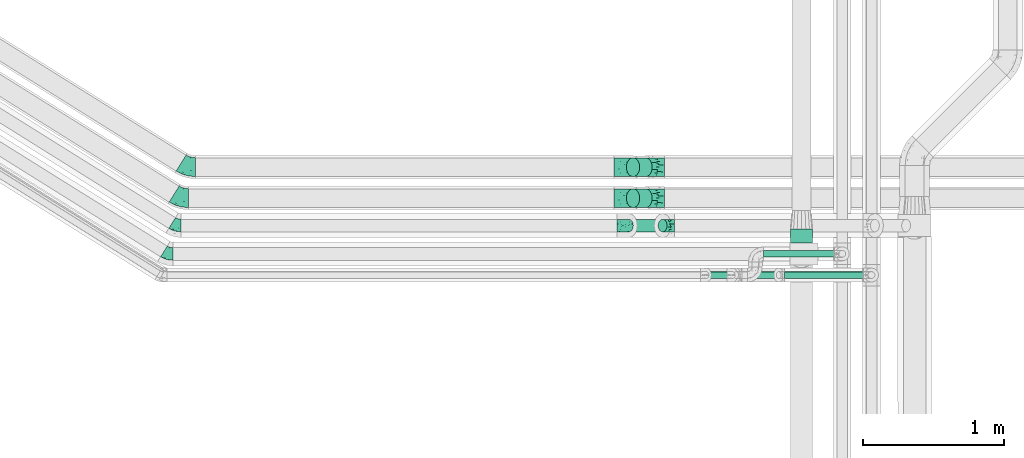
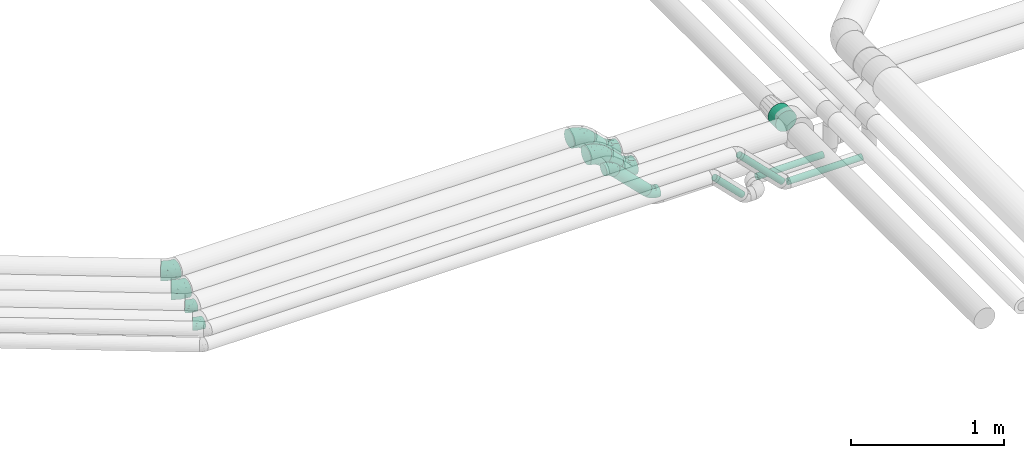
# One storey, part 65 of 93: 10 flow fittings, 8 flow segments.
"""IFC2X3 building model written with IfcOpenShell, lengths in millimetres."""

from ifc_helpers import new_model, entity, si_unit, converted_unit, derived_unit, direction, frame, origin, origin_2d_with_axis, place, context, subcontext, project, spatial, circle, extrude, faceted_brep, source, transform, mapped, material, type_object, type_shapes, element, save


model = new_model("IFC2X3")

# Units and contexts
model_context = context("Model", 3, precision=0.01, world=origin(), true_north=direction((6.12303176911189e-17, 1.0)))
body_context = subcontext(model_context, "Body", "Model", "MODEL_VIEW")
ifc_project = project(units=[si_unit("LENGTHUNIT", "METRE", prefix="MILLI"), si_unit("AREAUNIT", "SQUARE_METRE"), si_unit("VOLUMEUNIT", "CUBIC_METRE"), converted_unit("PLANEANGLEUNIT", "DEGREE", entity("IfcRatioMeasure", 0.0174532925199433), si_unit("PLANEANGLEUNIT", "RADIAN"), dimensions=[0, 0, 0, 0, 0, 0, 0]), si_unit("MASSUNIT", "GRAM", prefix="KILO"), derived_unit("MASSDENSITYUNIT", [(si_unit("MASSUNIT", "GRAM", prefix="KILO"), 1), (si_unit("LENGTHUNIT", "METRE"), -3)]), derived_unit("MOMENTOFINERTIAUNIT", [(si_unit("LENGTHUNIT", "METRE"), 4)]), si_unit("TIMEUNIT", "SECOND"), si_unit("FREQUENCYUNIT", "HERTZ"), si_unit("THERMODYNAMICTEMPERATUREUNIT", "DEGREE_CELSIUS"), derived_unit("THERMALTRANSMITTANCEUNIT", [(si_unit("MASSUNIT", "GRAM", prefix="KILO"), 1), (si_unit("THERMODYNAMICTEMPERATUREUNIT", "KELVIN"), -1), (si_unit("TIMEUNIT", "SECOND"), -3)]), derived_unit("VOLUMETRICFLOWRATEUNIT", [(si_unit("LENGTHUNIT", "METRE"), 3), (si_unit("TIMEUNIT", "SECOND"), -1)]), derived_unit("MASSFLOWRATEUNIT", [(si_unit("MASSUNIT", "GRAM", prefix="KILO"), 1), (si_unit("TIMEUNIT", "SECOND"), -1)]), derived_unit("ROTATIONALFREQUENCYUNIT", [(si_unit("TIMEUNIT", "SECOND"), -1)]), si_unit("ELECTRICCURRENTUNIT", "AMPERE"), si_unit("ELECTRICVOLTAGEUNIT", "VOLT"), si_unit("POWERUNIT", "WATT"), si_unit("FORCEUNIT", "NEWTON", prefix="KILO"), si_unit("ILLUMINANCEUNIT", "LUX"), si_unit("LUMINOUSFLUXUNIT", "LUMEN"), si_unit("LUMINOUSINTENSITYUNIT", "CANDELA"), derived_unit("USERDEFINED", [(si_unit("MASSUNIT", "GRAM", prefix="KILO"), -1), (si_unit("LENGTHUNIT", "METRE"), -2), (si_unit("TIMEUNIT", "SECOND"), 3), (si_unit("LUMINOUSFLUXUNIT", "LUMEN"), 1)]), derived_unit("LINEARVELOCITYUNIT", [(si_unit("LENGTHUNIT", "METRE"), 1), (si_unit("TIMEUNIT", "SECOND"), -1)]), si_unit("PRESSUREUNIT", "PASCAL"), derived_unit("USERDEFINED", [(si_unit("LENGTHUNIT", "METRE"), -2), (si_unit("MASSUNIT", "GRAM", prefix="KILO"), 1), (si_unit("TIMEUNIT", "SECOND"), -2)]), derived_unit("LINEARFORCEUNIT", [(si_unit("MASSUNIT", "GRAM", prefix="KILO"), 1), (si_unit("LENGTHUNIT", "METRE"), 1), (si_unit("TIMEUNIT", "SECOND"), -2), (si_unit("LENGTHUNIT", "METRE"), -1)]), derived_unit("PLANARFORCEUNIT", [(si_unit("MASSUNIT", "GRAM", prefix="KILO"), 1), (si_unit("LENGTHUNIT", "METRE"), 1), (si_unit("TIMEUNIT", "SECOND"), -2), (si_unit("LENGTHUNIT", "METRE"), -2)])], contexts=[model_context])

# Site, building, storey
site_placement = place(None, origin())
site = spatial("IfcSite", under=ifc_project, at=site_placement, CompositionType="ELEMENT")
building_placement = place(site_placement, origin())
building = spatial("IfcBuilding", under=site, at=building_placement, CompositionType="ELEMENT")
storey_placement = place(building_placement, frame((0.0, 0.0, -4200.0)))
storey = spatial("IfcBuildingStorey", under=building, at=storey_placement, CompositionType="ELEMENT", Elevation=-4200.0)

# Flow segments
pipe_segment_type_1 = type_object("IfcPipeSegmentType", PredefinedType="NOTDEFINED")
flow_segment_1_placement = place(storey_placement, frame((24098.2, 8937.48, 2919.66)))
element("IfcFlowSegment", 1, at=flow_segment_1_placement, inside=storey, type_object=pipe_segment_type_1, context=body_context, shape_type="SweptSolid", body=[
    extrude(circle(Radius=79.5, at=origin_2d_with_axis()), frame((81.1, 0.0, 81.1), z_axis=(0.0, 1.0, 0.0), x_axis=(-1.0, 0.0, 0.0)), (0.0, 0.0, 1.0), 101.158721386606),
])
flow_segment_2_placement = place(storey_placement, frame((22924.93, 9015.05, 2689.95)))
element("IfcFlowSegment", 2, at=flow_segment_2_placement, inside=storey, type_object=pipe_segment_type_1, context=body_context, shape_type="SweptSolid", body=[
    extrude(circle(Radius=44.5, at=origin_2d_with_axis()), frame((33.06, 46.1, 271.9), z_axis=(0.707106781186488, 0.0, -0.707106781186607), x_axis=(0.0, 1.0, 0.0)), (0.0, 0.0, 1.0), 337.768480583876),
])
flow_segment_3_placement = place(storey_placement, frame((22938.9, 9406.04, 2807.03)))
element("IfcFlowSegment", 3, at=flow_segment_3_placement, inside=storey, type_object=pipe_segment_type_1, context=body_context, shape_type="SweptSolid", body=[
    extrude(circle(Radius=66.5, at=origin_2d_with_axis()), frame((137.32, 68.1, 48.62), z_axis=(-0.707106781186337, 0.0, 0.707106781186758), x_axis=(0.0, 1.0, 0.0)), (0.0, 0.0, 1.0), 125.441558772783),
])
flow_segment_4_placement = place(storey_placement, frame((22938.9, 9186.64, 2807.03)))
element("IfcFlowSegment", 4, at=flow_segment_4_placement, inside=storey, type_object=pipe_segment_type_1, context=body_context, shape_type="SweptSolid", body=[
    extrude(circle(Radius=66.5, at=origin_2d_with_axis()), frame((137.32, 68.1, 48.62), z_axis=(-0.707106781186325, 0.0, 0.70710678118677), x_axis=(0.0, 1.0, 0.0)), (0.0, 0.0, 1.0), 125.441558772785),
])
pipe_segment_type_2 = type_object("IfcPipeSegmentType", PredefinedType="NOTDEFINED")
flow_segment_5_placement = place(storey_placement, frame((23488.33, 8685.55, 2698.13)))
element("IfcFlowSegment", 5, at=flow_segment_5_placement, inside=storey, type_object=pipe_segment_type_2, context=body_context, shape_type="SweptSolid", body=[
    extrude(circle(Radius=24.0, at=origin_2d_with_axis()), frame((228.02, 25.6, 18.57), z_axis=(-0.707106781186526, 0.0, 0.707106781186569), x_axis=(0.0, 1.0, 0.0)), (0.0, 0.0, 1.0), 296.211111394567),
])
flow_segment_6_placement = place(storey_placement, frame((23673.79, 8685.55, 2698.13)))
element("IfcFlowSegment", 6, at=flow_segment_6_placement, inside=storey, type_object=pipe_segment_type_2, context=body_context, shape_type="SweptSolid", body=[
    extrude(circle(Radius=24.0, at=origin_2d_with_axis()), frame((343.98, 25.6, 18.57), z_axis=(-0.707106781186481, 0.0, 0.707106781186614), x_axis=(0.0, 1.0, 0.0)), (0.0, 0.0, 1.0), 460.201010126802),
])
flow_segment_7_placement = place(storey_placement, frame((24058.07, 8685.55, 2674.4)))
element("IfcFlowSegment", 7, at=flow_segment_7_placement, inside=storey, type_object=pipe_segment_type_2, context=body_context, shape_type="SweptSolid", body=[
    extrude(circle(Radius=24.0, at=origin_2d_with_axis()), frame((0.0, 25.6, 25.6), z_axis=(1.0, 0.0, 0.0), x_axis=(0.0, -1.0, 0.0)), (0.0, 0.0, 1.0), 559.389826944779),
])
flow_segment_8_placement = place(storey_placement, frame((23910.05, 8835.55, 2674.4)))
element("IfcFlowSegment", 8, at=flow_segment_8_placement, inside=storey, type_object=pipe_segment_type_2, context=body_context, shape_type="SweptSolid", body=[
    extrude(circle(Radius=24.0, at=origin_2d_with_axis()), frame((0.0, 25.6, 25.6), z_axis=(1.0, 0.0, 0.0), x_axis=(0.0, 1.0, 0.0)), (0.0, 0.0, 1.0), 501.000000000012),
])

# Flow fittings
ifc_material = material()
pipe_fitting_type_1 = type_object("IfcPipeFittingType", Name="ADSK_2", PredefinedType="NOTDEFINED", material=ifc_material)
shared_shape_1 = source(origin(), body_context, "Body", "Brep", [
    faceted_brep([(-78.7, 33.25, -57.59), (-78.7, 17.21, -64.23), (-78.7, 0.0, -66.5), (-78.7, -17.21, -64.23), (-78.7, -33.25, -57.59), (-78.7, -47.02, -47.02), (-78.7, -57.59, -33.25), (-78.7, -64.23, -17.21), (-78.7, -66.5, 0.0), (-78.7, -64.23, 17.21), (-78.7, -57.59, 33.25), (-78.7, -47.02, 47.02), (-78.7, -33.25, 57.59), (-78.7, -17.21, 64.23), (-78.7, 0.0, 66.5), (-78.7, 17.21, 64.23), (-78.7, 33.25, 57.59), (-78.7, 47.02, 47.02), (-78.7, 57.59, 33.25), (-78.7, 64.23, 17.21), (-78.7, 66.5, 0.0), (-78.7, 64.23, -17.21), (-78.7, 57.59, -33.25), (-78.7, 47.02, -47.02), (55.65, 55.65, -66.5), (43.48, 67.82, -64.23), (32.14, 79.16, -57.59), (22.4, 88.9, -47.02), (14.93, 96.37, -33.25), (10.23, 101.07, -17.21), (8.63, 102.67, 0.0), (10.23, 101.07, 17.21), (14.93, 96.37, 33.25), (22.4, 88.9, 47.02), (32.14, 79.16, 57.59), (43.48, 67.82, 64.23), (55.65, 55.65, 66.5), (67.82, 43.48, 64.23), (79.16, 32.14, 57.59), (88.9, 22.4, 47.02), (96.37, 14.93, 33.25), (101.07, 10.23, 17.21), (102.67, 8.63, 0.0), (101.07, 10.23, -17.21), (96.37, 14.93, -33.25), (88.9, 22.4, -47.02), (79.16, 32.14, -57.59), (67.82, 43.48, -64.23), (-40.01, -57.38, 27.86), (-40.6, -61.75, 15.74), (-6.41, -52.87, 20.07), (-28.66, -61.57, 0.0), (44.74, 12.16, 61.0), (-23.71, -35.12, 51.77), (8.73, -21.07, 54.25), (-40.23, -23.04, 61.0), (-34.61, -49.5, 39.47), (-28.9, -3.87, 65.72), (-8.47, 20.45, 66.18), (-47.15, 10.46, 66.05), (-49.81, 55.22, 41.25), (-33.77, 66.88, 30.79), (-20.88, 50.42, 53.92), (7.4, 48.4, 61.91), (-34.71, 30.07, 61.97), (42.4, -35.06, 11.04), (19.46, -46.98, 0.0), (63.8, -23.27, 0.0), (-15.18, 67.35, 41.6), (14.82, -35.78, 38.27), (53.98, -24.32, 23.88), (-30.55, 73.76, 17.41), (-46.74, 70.71, 0.0), (59.47, -10.53, 39.47), (-16.95, 83.05, 0.0), (25.95, 40.74, 66.05), (41.59, -8.07, 51.77), (23.18, 17.7, 65.72), (74.36, -14.41, 12.26), (4.62, -11.15, 60.44), (-39.45, 28.99, -61.91), (-20.88, 50.42, -53.92), (3.28, 45.81, -61.97), (-23.41, 71.18, -30.79), (8.73, -21.07, -54.25), (4.62, -11.15, -60.44), (44.74, 12.16, -61.0), (-30.55, 73.76, -17.41), (-40.23, -23.04, -61.0), (-23.71, -35.12, -51.77), (-36.89, 58.36, -41.6), (-47.15, 10.46, -66.05), (-28.9, -3.87, -65.72), (-20.98, -55.37, -23.88), (-34.61, -49.5, -39.47), (68.86, -12.28, -27.86), (59.47, -10.53, -39.47), (-42.39, -62.77, -12.26), (41.59, -8.07, -51.77), (14.82, -35.78, -38.27), (41.92, -32.85, -20.07), (-5.19, -54.78, -11.04), (72.37, -14.95, -15.74), (-3.83, 74.27, -41.25), (25.95, 40.74, -66.05), (23.18, 17.7, -65.72), (-8.47, 20.45, -66.18)], [[[0, 1, 2, 3, 4, 5, 6, 7, 8, 9, 10, 11, 12, 13, 14, 15, 16, 17, 18, 19, 20, 21, 22, 23]], [[24, 25, 26, 27, 28, 29, 30, 31, 32, 33, 34, 35, 36, 37, 38, 39, 40, 41, 42, 43, 44, 45, 46, 47]], [[48, 49, 50]], [[49, 8, 51]], [[38, 37, 52]], [[12, 11, 53]], [[53, 54, 55]], [[56, 11, 10]], [[14, 13, 57]], [[13, 12, 55]], [[57, 58, 59]], [[60, 61, 18]], [[62, 63, 34]], [[18, 61, 19]], [[16, 15, 64]], [[17, 16, 62]], [[65, 66, 67]], [[60, 62, 68]], [[15, 14, 59]], [[34, 33, 62]], [[69, 50, 70]], [[19, 71, 72]], [[40, 39, 73]], [[72, 20, 19]], [[74, 71, 31]], [[50, 66, 65]], [[62, 16, 64]], [[56, 48, 69]], [[66, 50, 51]], [[36, 35, 75]], [[39, 38, 76]], [[76, 73, 39]], [[32, 31, 61]], [[75, 77, 36]], [[70, 41, 40]], [[77, 37, 36]], [[48, 56, 10]], [[70, 40, 73]], [[59, 64, 15]], [[76, 38, 52]], [[58, 75, 63]], [[42, 41, 78]], [[53, 56, 69]], [[17, 60, 18]], [[54, 79, 55]], [[72, 71, 74]], [[48, 9, 49]], [[30, 74, 31]], [[54, 69, 76]], [[31, 71, 61]], [[58, 57, 77]], [[32, 68, 33]], [[55, 57, 13]], [[68, 62, 33]], [[79, 52, 77]], [[35, 34, 63]], [[63, 62, 64]], [[73, 76, 69]], [[79, 77, 57]], [[78, 70, 65]], [[70, 73, 69]], [[56, 53, 11]], [[58, 63, 64]], [[53, 55, 12]], [[57, 55, 79]], [[77, 52, 37]], [[52, 79, 54]], [[57, 59, 14]], [[64, 59, 58]], [[63, 75, 35]], [[77, 75, 58]], [[62, 60, 17]], [[61, 60, 68]], [[32, 61, 68]], [[61, 71, 19]], [[9, 48, 10]], [[69, 48, 50]], [[8, 49, 9]], [[51, 50, 49]], [[78, 65, 67]], [[50, 65, 70]], [[42, 78, 67]], [[70, 78, 41]], [[69, 54, 53]], [[52, 54, 76]], [[1, 0, 80]], [[81, 82, 80]], [[28, 83, 29]], [[23, 81, 0]], [[20, 72, 21]], [[84, 85, 86]], [[21, 87, 83]], [[88, 89, 4]], [[81, 23, 90]], [[91, 92, 2]], [[26, 25, 82]], [[91, 2, 1]], [[93, 6, 94]], [[95, 96, 44]], [[8, 7, 97]], [[81, 80, 0]], [[93, 7, 6]], [[98, 96, 99]], [[88, 4, 3]], [[100, 66, 101]], [[6, 5, 94]], [[89, 5, 4]], [[2, 92, 3]], [[94, 89, 99]], [[93, 94, 99]], [[96, 98, 45]], [[87, 72, 74]], [[89, 94, 5]], [[74, 30, 29]], [[99, 100, 93]], [[72, 87, 21]], [[95, 43, 102]], [[103, 83, 28]], [[90, 103, 81]], [[26, 82, 81]], [[46, 45, 98]], [[104, 25, 24]], [[96, 95, 99]], [[22, 90, 23]], [[26, 81, 27]], [[84, 99, 89]], [[104, 105, 106]], [[84, 86, 98]], [[27, 103, 28]], [[24, 47, 105]], [[67, 66, 100]], [[44, 96, 45]], [[47, 46, 86]], [[100, 95, 102]], [[85, 92, 105]], [[67, 102, 42]], [[85, 88, 92]], [[106, 105, 92]], [[97, 93, 101]], [[22, 21, 83]], [[101, 66, 51]], [[104, 82, 25]], [[87, 74, 29]], [[106, 91, 80]], [[86, 105, 47]], [[106, 80, 82]], [[92, 88, 3]], [[88, 85, 84]], [[98, 86, 46]], [[105, 86, 85]], [[80, 91, 1]], [[92, 91, 106]], [[105, 104, 24]], [[82, 104, 106]], [[81, 103, 27]], [[83, 103, 90]], [[22, 83, 90]], [[83, 87, 29]], [[43, 95, 44]], [[99, 95, 100]], [[42, 102, 43]], [[67, 100, 102]], [[97, 101, 51]], [[100, 101, 93]], [[8, 97, 51]], [[93, 97, 7]], [[99, 84, 98]], [[88, 84, 89]]]),
])
type_shapes(pipe_fitting_type_1, [shared_shape_1])
for number, where, z_axis, x_axis, name in (
    (9, (22931.87, 9474.14, 3000.0), (0.0, -1.0, 0.0), (-0.70710678118647, 0.0, 0.707106781186625), "ADSK_2"),
    (10, (23131.87, 9254.74, 2800.0), (0.0, 1.0, 0.0), (-1.0, 0.0, 0.0), "ADSK_2"),
    (11, (22931.87, 9254.74, 3000.0), (0.0, -1.0, 0.0), (-0.707106781186467, 0.0, 0.707106781186629), "ADSK_2"),
    (12, (23131.87, 9474.14, 2800.0), (0.0, -1.0, 0.0), (0.707106781186337, 0.0, -0.707106781186758), "ADSK_2"),
):
    element("IfcFlowFitting", number, at=place(storey_placement, frame(where, z_axis=z_axis, x_axis=x_axis)), inside=storey, type_object=pipe_fitting_type_1, material=ifc_material, Name=name, ObjectType="ADSK_2", context=body_context, shape_type="MappedRepresentation", body=[
        mapped(shared_shape_1, transform((0.0, 0.0, 0.0), scale=1.0)),
    ])
pipe_fitting_type_2 = type_object("IfcPipeFittingType", Name="ADSK_2", PredefinedType="NOTDEFINED", material=ifc_material)
shared_shape_2 = source(origin(), body_context, "Body", "Brep", [
    faceted_brep([(-49.71, 22.25, -38.54), (-49.71, 11.52, -42.98), (-49.71, 0.0, -44.5), (-49.71, -11.52, -42.98), (-49.71, -22.25, -38.54), (-49.71, -31.47, -31.47), (-49.71, -38.54, -22.25), (-49.71, -42.98, -11.52), (-49.71, -44.5, 0.0), (-49.71, -42.98, 11.52), (-49.71, -38.54, 22.25), (-49.71, -31.47, 31.47), (-49.71, -22.25, 38.54), (-49.71, -11.52, 42.98), (-49.71, 0.0, 44.5), (-49.71, 11.52, 42.98), (-49.71, 22.25, 38.54), (-49.71, 31.47, 31.47), (-49.71, 38.54, 22.25), (-49.71, 42.98, 11.52), (-49.71, 44.5, 0.0), (-49.71, 42.98, -11.52), (-49.71, 38.54, -22.25), (-49.71, 31.47, -31.47), (7.9, 62.4, -22.25), (4.75, 65.54, -11.52), (3.68, 66.61, 0.0), (4.75, 65.54, 11.52), (7.9, 62.4, 22.25), (12.9, 57.4, 31.47), (19.41, 50.88, 38.54), (27.0, 43.29, 42.98), (35.15, 35.15, 44.5), (43.29, 27.0, 42.98), (50.88, 19.41, 38.54), (57.4, 12.9, 31.47), (62.4, 7.9, 22.25), (65.54, 4.75, 11.52), (66.61, 3.68, 0.0), (65.54, 4.75, -11.52), (62.4, 7.9, -22.25), (57.4, 12.9, -31.47), (50.88, 19.41, -38.54), (43.29, 27.0, -42.98), (35.15, 35.15, -44.5), (27.0, 43.29, -42.98), (19.41, 50.88, -38.54), (12.9, 57.4, -31.47), (-21.43, -33.27, 26.36), (-12.91, -37.31, 15.91), (10.17, -24.56, 25.5), (-27.71, -41.6, 0.0), (-7.13, -38.89, 0.0), (-18.38, -40.78, 7.83), (-14.74, -23.79, 34.6), (38.68, -8.37, 26.36), (6.12, -14.78, 36.19), (-25.19, -15.57, 40.8), (16.24, 25.94, 44.2), (-18.21, -2.89, 43.97), (-5.41, 13.06, 44.3), (-29.82, 6.86, 44.2), (27.25, -6.4, 34.6), (28.82, 6.8, 40.8), (-22.09, 19.83, 41.49), (-13.73, 33.15, 36.12), (12.63, -28.35, 17.49), (12.91, -31.18, 8.74), (-24.73, 38.45, 27.84), (-19.34, 46.69, 18.1), (41.83, -15.84, 7.83), (49.01, -9.83, 0.0), (-20.81, 50.25, 0.0), (14.92, 10.84, 43.97), (3.35, -8.1, 40.4), (-3.82, 48.3, 27.64), (35.51, -17.26, 15.91), (4.26, 31.34, 41.45), (-14.33, 52.2, 9.25), (12.71, -30.68, 0.0), (32.54, -22.46, 0.0), (-18.21, -2.89, -43.97), (-18.38, -40.78, -7.83), (12.91, -31.16, -8.82), (1.59, 29.64, -41.49), (-29.82, 6.86, -44.2), (-19.34, 46.69, -18.1), (27.25, -6.4, -34.6), (-13.73, 33.15, -36.12), (35.51, -17.26, -15.91), (-31.45, 36.86, -27.64), (14.92, 10.84, -43.97), (-26.78, 47.05, -9.25), (-25.18, 19.14, -41.45), (-12.91, -37.31, -15.91), (38.68, -8.37, -26.36), (-21.43, -33.27, -26.36), (10.17, -24.56, -25.5), (-14.74, -23.79, -34.6), (6.12, -14.78, -36.19), (3.35, -8.1, -40.4), (28.82, 6.8, -40.8), (-25.19, -15.57, -40.8), (-9.7, 44.68, -27.84), (41.83, -15.84, -7.83), (16.24, 25.94, -44.2), (-5.41, 13.06, -44.3), (10.98, -29.02, -17.53)], [[[0, 1, 2, 3, 4, 5, 6, 7, 8, 9, 10, 11, 12, 13, 14, 15, 16, 17, 18, 19, 20, 21, 22, 23]], [[24, 25, 26, 27, 28, 29, 30, 31, 32, 33, 34, 35, 36, 37, 38, 39, 40, 41, 42, 43, 44, 45, 46, 47]], [[48, 49, 50]], [[51, 52, 53]], [[12, 11, 54]], [[36, 35, 55]], [[54, 56, 57]], [[48, 11, 10]], [[32, 31, 58]], [[13, 12, 57]], [[59, 60, 61]], [[14, 13, 59]], [[62, 55, 35]], [[34, 33, 63]], [[61, 15, 14]], [[16, 64, 65]], [[9, 51, 53]], [[30, 29, 65]], [[66, 49, 67]], [[65, 17, 16]], [[18, 17, 68]], [[18, 68, 69]], [[19, 18, 69]], [[37, 70, 71]], [[19, 72, 20]], [[52, 67, 53]], [[49, 53, 67]], [[16, 15, 64]], [[32, 58, 73]], [[35, 34, 62]], [[74, 73, 59]], [[73, 33, 32]], [[75, 65, 29]], [[76, 36, 55]], [[60, 58, 77]], [[62, 34, 63]], [[17, 65, 68]], [[70, 37, 76]], [[49, 48, 10]], [[61, 64, 15]], [[56, 50, 62]], [[19, 69, 78]], [[10, 9, 49]], [[72, 78, 26]], [[48, 54, 11]], [[27, 78, 69]], [[74, 63, 73]], [[69, 68, 75]], [[55, 62, 50]], [[28, 75, 29]], [[57, 59, 13]], [[31, 30, 77]], [[77, 65, 64]], [[56, 74, 57]], [[60, 59, 73]], [[76, 37, 36]], [[54, 48, 50]], [[28, 27, 69]], [[76, 55, 50]], [[65, 77, 30]], [[60, 77, 64]], [[54, 57, 12]], [[59, 57, 74]], [[73, 63, 33]], [[63, 74, 56]], [[9, 8, 51]], [[67, 52, 79, 80]], [[9, 53, 49]], [[70, 67, 80]], [[67, 76, 66]], [[71, 70, 80]], [[71, 38, 37]], [[67, 70, 76]], [[59, 61, 14]], [[64, 61, 60]], [[77, 58, 31]], [[73, 58, 60]], [[69, 75, 28]], [[65, 75, 68]], [[26, 78, 27]], [[19, 78, 72]], [[50, 56, 54]], [[63, 56, 62]], [[76, 50, 66]], [[49, 66, 50]], [[81, 3, 2]], [[52, 82, 83]], [[46, 45, 84]], [[2, 1, 85]], [[86, 22, 21]], [[42, 41, 87]], [[88, 0, 23]], [[40, 39, 89]], [[22, 90, 23]], [[44, 43, 91]], [[86, 21, 92]], [[93, 1, 0]], [[82, 7, 94]], [[89, 95, 40]], [[94, 96, 97]], [[96, 94, 6]], [[5, 4, 98]], [[99, 100, 101]], [[7, 6, 94]], [[5, 96, 6]], [[102, 4, 3]], [[90, 88, 23]], [[98, 96, 5]], [[24, 47, 103]], [[20, 72, 92]], [[47, 88, 103]], [[72, 26, 25]], [[99, 97, 98]], [[88, 84, 93]], [[24, 86, 25]], [[47, 46, 88]], [[102, 98, 4]], [[84, 88, 46]], [[103, 90, 86]], [[85, 81, 2]], [[103, 86, 24]], [[39, 71, 104]], [[105, 45, 44]], [[101, 43, 42]], [[7, 82, 51]], [[40, 95, 41]], [[101, 87, 99]], [[95, 87, 41]], [[106, 105, 91]], [[97, 95, 89]], [[106, 91, 81]], [[104, 71, 80]], [[101, 91, 43]], [[100, 102, 81]], [[82, 94, 83]], [[100, 81, 91]], [[107, 89, 83]], [[105, 84, 45]], [[25, 86, 92]], [[106, 85, 93]], [[96, 98, 97]], [[87, 95, 97]], [[88, 93, 0]], [[106, 93, 84]], [[81, 102, 3]], [[102, 100, 99]], [[87, 101, 42]], [[91, 101, 100]], [[51, 82, 52]], [[51, 8, 7]], [[107, 83, 94]], [[104, 83, 89]], [[83, 80, 79, 52]], [[39, 38, 71]], [[83, 104, 80]], [[39, 104, 89]], [[93, 85, 1]], [[81, 85, 106]], [[91, 105, 44]], [[84, 105, 106]], [[86, 90, 22]], [[88, 90, 103]], [[20, 92, 21]], [[25, 92, 72]], [[97, 99, 87]], [[102, 99, 98]], [[94, 97, 107]], [[89, 107, 97]]]),
])
type_shapes(pipe_fitting_type_2, [shared_shape_2])
for number, where, z_axis, x_axis, name in (
    (13, (23231.98, 9061.14, 2687.87), (0.0, 1.0, 0.0), (-1.0, 0.0, 0.0), "ADSK_2"),
    (14, (22922.85, 9061.14, 2997.0), (0.0, -1.0, 0.0), (-0.707106781186506, 0.0, 0.70710678118659), "ADSK_2"),
):
    element("IfcFlowFitting", number, at=place(storey_placement, frame(where, z_axis=z_axis, x_axis=x_axis)), inside=storey, type_object=pipe_fitting_type_2, material=ifc_material, Name=name, ObjectType="ADSK_2", context=body_context, shape_type="MappedRepresentation", body=[
        mapped(shared_shape_2, transform((0.0, 0.0, 0.0), scale=1.0)),
    ])
pipe_fitting_type_3 = type_object("IfcPipeFittingType", Name="ADSK_2", PredefinedType="NOTDEFINED", material=ifc_material)
shared_shape_3 = source(origin(), body_context, "Body", "Brep", [
    faceted_brep([(-34.41, 22.25, -38.54), (-34.41, 11.52, -42.98), (-34.41, 0.0, -44.5), (-34.41, -11.52, -42.98), (-34.41, -22.25, -38.54), (-34.41, -31.47, -31.47), (-34.41, -38.54, -22.25), (-34.41, -42.98, -11.52), (-34.41, -44.5, 0.0), (-34.41, -42.98, 11.52), (-34.41, -38.54, 22.25), (-34.41, -31.47, 31.47), (-34.41, -22.25, 38.54), (-34.41, -11.52, 42.98), (-34.41, 0.0, 44.5), (-34.41, 11.52, 42.98), (-34.41, 22.25, 38.54), (-34.41, 31.47, 31.47), (-34.41, 38.54, 22.25), (-34.41, 42.98, 11.52), (-34.41, 44.5, 0.0), (-34.41, 42.98, -11.52), (-34.41, 38.54, -22.25), (-34.41, 31.47, -31.47), (29.18, 18.23, -44.5), (23.08, 28.0, -42.98), (17.39, 37.1, -38.54), (12.51, 44.92, -31.47), (8.76, 50.92, -22.25), (6.4, 54.69, -11.52), (5.6, 55.97, 0.0), (6.4, 54.69, 11.52), (8.76, 50.92, 22.25), (12.51, 44.92, 31.47), (17.39, 37.1, 38.54), (23.08, 28.0, 42.98), (29.18, 18.23, 44.5), (35.28, 8.47, 42.98), (40.97, -0.63, 38.54), (45.86, -8.45, 31.47), (49.6, -14.45, 22.25), (51.96, -18.22, 11.52), (52.76, -19.5, 0.0), (51.96, -18.22, -11.52), (49.6, -14.45, -22.25), (45.86, -8.45, -31.47), (40.97, -0.63, -38.54), (35.28, 8.47, -42.98), (-9.95, -41.09, 11.69), (-3.96, -41.66, 0.0), (-3.73, -32.68, 26.53), (10.11, -35.25, 16.06), (29.72, -26.56, 19.54), (25.39, -23.71, 26.62), (6.34, -22.11, 34.72), (0.5, -1.74, 44.0), (-5.22, -14.53, 40.85), (-7.6, 8.32, 44.2), (-5.84, 20.36, 41.39), (-7.81, 30.42, 35.71), (-10.96, 38.21, 27.6), (-12.6, 43.95, 17.57), (19.97, -6.26, 40.92), (-13.34, 46.53, 9.05), (30.22, -29.57, 11.69), (25.43, -33.23, 0.0), (10.77, -37.56, 7.2), (-13.6, 47.42, 0.0), (0.5, -1.74, -44.0), (10.17, -35.46, -15.47), (-11.1, -41.03, -12.48), (-8.27, -37.69, -19.81), (2.04, 11.08, -44.2), (-12.6, 43.95, -17.57), (-10.96, 38.21, -27.6), (20.48, -25.74, -26.53), (-5.84, 20.36, -41.39), (6.34, -22.11, -34.72), (-8.96, -33.56, -26.62), (-13.34, 46.53, -9.05), (12.13, -9.55, -40.85), (-9.5, 29.94, -35.71), (7.38, -38.48, -7.3), (29.1, -30.67, -9.34), (-13.62, -15.9, -40.92)], [[[0, 1, 2, 3, 4, 5, 6, 7, 8, 9, 10, 11, 12, 13, 14, 15, 16, 17, 18, 19, 20, 21, 22, 23]], [[24, 25, 26, 27, 28, 29, 30, 31, 32, 33, 34, 35, 36, 37, 38, 39, 40, 41, 42, 43, 44, 45, 46, 47]], [[48, 10, 9]], [[48, 8, 49]], [[11, 10, 50]], [[51, 52, 53]], [[11, 54, 12]], [[11, 50, 54]], [[37, 36, 55]], [[56, 55, 13]], [[55, 14, 13]], [[13, 12, 56]], [[10, 48, 51]], [[39, 38, 54]], [[15, 57, 58]], [[58, 16, 15]], [[10, 51, 50]], [[35, 34, 58]], [[12, 54, 56]], [[59, 16, 58]], [[60, 59, 33]], [[60, 18, 17]], [[19, 18, 61]], [[62, 54, 38]], [[63, 20, 19]], [[64, 52, 51]], [[49, 65, 66]], [[15, 14, 57]], [[62, 38, 37]], [[56, 62, 55]], [[51, 53, 50]], [[57, 35, 58]], [[48, 66, 51]], [[54, 50, 53]], [[20, 63, 67]], [[39, 53, 40]], [[65, 42, 64]], [[42, 41, 64]], [[65, 64, 66]], [[30, 63, 31]], [[36, 57, 55]], [[63, 19, 61]], [[48, 49, 66]], [[67, 63, 30]], [[14, 55, 57]], [[31, 63, 61]], [[32, 31, 61]], [[34, 59, 58]], [[33, 32, 60]], [[32, 61, 60]], [[60, 61, 18]], [[34, 33, 59]], [[57, 36, 35]], [[59, 60, 17]], [[54, 53, 39]], [[66, 64, 51]], [[52, 41, 40]], [[16, 59, 17]], [[48, 9, 8]], [[41, 52, 64]], [[40, 53, 52]], [[55, 62, 37]], [[54, 62, 56]], [[3, 2, 68]], [[69, 70, 71]], [[25, 24, 72]], [[72, 2, 1]], [[22, 73, 74]], [[45, 44, 75]], [[1, 0, 76]], [[77, 75, 78]], [[21, 79, 73]], [[47, 46, 80]], [[74, 81, 23]], [[0, 81, 76]], [[49, 8, 7]], [[65, 82, 83]], [[44, 83, 69]], [[70, 69, 82]], [[77, 5, 4]], [[28, 27, 74]], [[43, 42, 83]], [[6, 5, 78]], [[3, 84, 4]], [[77, 84, 80]], [[82, 65, 49]], [[26, 81, 27]], [[20, 67, 79]], [[68, 84, 3]], [[30, 29, 79]], [[2, 72, 68]], [[1, 76, 72]], [[73, 22, 21]], [[81, 26, 76]], [[71, 6, 78]], [[26, 25, 76]], [[0, 23, 81]], [[68, 80, 84]], [[74, 23, 22]], [[44, 69, 75]], [[25, 72, 76]], [[47, 80, 68]], [[84, 77, 4]], [[77, 45, 75]], [[46, 45, 77]], [[24, 68, 72]], [[24, 47, 68]], [[69, 83, 82]], [[77, 78, 5]], [[65, 83, 42]], [[29, 28, 73]], [[74, 73, 28]], [[83, 44, 43]], [[71, 75, 69]], [[46, 77, 80]], [[20, 79, 21]], [[79, 29, 73]], [[30, 79, 67]], [[81, 74, 27]], [[70, 49, 7]], [[49, 70, 82]], [[6, 70, 7]], [[6, 71, 70]], [[75, 71, 78]]]),
])
type_shapes(pipe_fitting_type_3, [shared_shape_3])
for number, where, z_axis, x_axis, name in (
    (15, (19697.94, 8859.98, 3000.76), (0.0, 0.0, 1.0), (0.848048096872162, -0.529919263087788, 0.0), "ADSK_2"),
    (16, (19756.09, 9061.14, 2997.0), (0.0, 0.0, 1.0), (0.848048096872166, -0.529919263087782, 0.0), "ADSK_2"),
):
    element("IfcFlowFitting", number, at=place(storey_placement, frame(where, z_axis=z_axis, x_axis=x_axis)), inside=storey, type_object=pipe_fitting_type_3, material=ifc_material, Name=name, ObjectType="ADSK_2", context=body_context, shape_type="MappedRepresentation", body=[
        mapped(shared_shape_3, transform((0.0, 0.0, 0.0), scale=1.0)),
    ])
pipe_fitting_type_4 = type_object("IfcPipeFittingType", Name="ADSK_2", PredefinedType="NOTDEFINED", material=ifc_material)
shared_shape_4 = source(origin(), body_context, "Body", "Brep", [
    faceted_brep([(-54.48, 33.25, -57.59), (-54.48, 17.21, -64.23), (-54.48, 0.0, -66.5), (-54.48, -17.21, -64.23), (-54.48, -33.25, -57.59), (-54.48, -47.02, -47.02), (-54.48, -57.59, -33.25), (-54.48, -64.23, -17.21), (-54.48, -66.5, 0.0), (-54.48, -64.23, 17.21), (-54.48, -57.59, 33.25), (-54.48, -47.02, 47.02), (-54.48, -33.25, 57.59), (-54.48, -17.21, 64.23), (-54.48, 0.0, 66.5), (-54.48, 17.21, 64.23), (-54.48, 33.25, 57.59), (-54.48, 47.02, 47.02), (-54.48, 57.59, 33.25), (-54.48, 64.23, 17.21), (-54.48, 66.5, 0.0), (-54.48, 64.23, -17.21), (-54.48, 57.59, -33.25), (-54.48, 47.02, -47.02), (46.2, 28.87, -66.5), (37.08, 43.47, -64.23), (28.58, 57.07, -57.59), (21.28, 68.75, -47.02), (15.68, 77.71, -33.25), (12.16, 83.34, -17.21), (10.96, 85.27, 0.0), (12.16, 83.34, 17.21), (15.68, 77.71, 33.25), (21.28, 68.75, 47.02), (28.58, 57.07, 57.59), (37.08, 43.47, 64.23), (46.2, 28.87, 66.5), (55.32, 14.27, 64.23), (63.82, 0.67, 57.59), (71.12, -11.01, 47.02), (76.72, -19.97, 33.25), (80.24, -25.6, 17.21), (81.44, -27.52, 0.0), (80.24, -25.6, -17.21), (76.72, -19.97, -33.25), (71.12, -11.01, -47.02), (63.82, 0.67, -57.59), (55.32, 14.27, -64.23), (-14.11, -61.85, 13.76), (-7.0, -62.07, 0.0), (-6.18, -48.52, 39.69), (9.34, -32.56, 51.94), (39.22, -34.48, 39.84), (0.61, -2.12, 65.77), (-8.42, -21.38, 61.06), (20.98, -54.24, 10.7), (-12.0, 12.76, 66.05), (-8.86, 30.88, 61.83), (15.11, -52.71, 22.75), (-11.34, 46.06, 53.33), (-16.5, 57.53, 41.21), (-18.95, 66.1, 26.23), (31.13, -8.39, 61.18), (-19.41, 70.16, 13.39), (47.71, -42.47, 18.27), (41.91, -40.24, 29.48), (-20.44, 71.28, 0.0), (38.83, -48.92, 0.0), (0.61, -2.12, -65.77), (9.34, -32.56, -51.94), (18.47, -13.67, -61.06), (3.41, 17.18, -66.05), (-18.95, 66.1, -26.23), (30.95, -37.87, -39.69), (-8.86, 30.88, -61.83), (-14.99, -50.02, -39.84), (-16.5, 57.53, -41.21), (-14.79, 45.07, -53.33), (-17.96, -61.3, -18.27), (10.96, -57.12, -10.7), (44.74, -44.97, -13.76), (15.11, -52.71, -22.75), (-21.96, -23.61, -61.18), (-20.72, 69.79, -13.39), (-14.21, -56.34, -29.48)], [[[0, 1, 2, 3, 4, 5, 6, 7, 8, 9, 10, 11, 12, 13, 14, 15, 16, 17, 18, 19, 20, 21, 22, 23]], [[24, 25, 26, 27, 28, 29, 30, 31, 32, 33, 34, 35, 36, 37, 38, 39, 40, 41, 42, 43, 44, 45, 46, 47]], [[48, 10, 9]], [[48, 8, 49]], [[11, 10, 50]], [[51, 50, 52]], [[11, 51, 12]], [[11, 50, 51]], [[37, 36, 53]], [[54, 53, 13]], [[53, 14, 13]], [[13, 12, 54]], [[49, 55, 48]], [[39, 38, 51]], [[15, 56, 57]], [[57, 16, 15]], [[10, 58, 50]], [[35, 34, 57]], [[12, 51, 54]], [[59, 16, 57]], [[60, 59, 33]], [[60, 18, 17]], [[19, 18, 61]], [[62, 51, 38]], [[63, 20, 19]], [[58, 64, 65]], [[55, 58, 48]], [[15, 14, 56]], [[62, 38, 37]], [[54, 62, 53]], [[65, 50, 58]], [[56, 35, 57]], [[51, 62, 54]], [[8, 48, 9]], [[63, 66, 20]], [[39, 52, 40]], [[53, 62, 37]], [[42, 41, 64]], [[55, 49, 67]], [[30, 63, 31]], [[36, 56, 53]], [[19, 61, 63]], [[65, 40, 52]], [[66, 63, 30]], [[14, 53, 56]], [[31, 63, 61]], [[32, 31, 61]], [[34, 59, 57]], [[33, 32, 60]], [[32, 61, 60]], [[60, 61, 18]], [[34, 33, 59]], [[56, 36, 35]], [[59, 60, 17]], [[51, 52, 39]], [[55, 64, 58]], [[10, 48, 58]], [[16, 59, 17]], [[67, 42, 64]], [[67, 64, 55]], [[65, 41, 40]], [[65, 64, 41]], [[50, 65, 52]], [[3, 2, 68]], [[46, 69, 70]], [[25, 24, 71]], [[71, 2, 1]], [[72, 22, 21]], [[45, 44, 73]], [[1, 0, 74]], [[69, 73, 75]], [[72, 76, 22]], [[47, 46, 70]], [[24, 68, 71]], [[0, 77, 74]], [[8, 7, 78]], [[67, 79, 80]], [[44, 80, 81]], [[78, 81, 79]], [[69, 5, 4]], [[68, 82, 3]], [[43, 42, 80]], [[6, 5, 75]], [[3, 82, 4]], [[69, 82, 70]], [[79, 67, 49]], [[82, 69, 4]], [[20, 66, 83]], [[83, 66, 30]], [[30, 29, 83]], [[26, 77, 27]], [[1, 74, 71]], [[28, 72, 29]], [[77, 26, 74]], [[84, 6, 75]], [[26, 25, 74]], [[0, 23, 77]], [[68, 70, 82]], [[76, 23, 22]], [[81, 78, 84]], [[25, 71, 74]], [[47, 70, 68]], [[76, 77, 23]], [[69, 45, 73]], [[46, 45, 69]], [[69, 75, 5]], [[24, 47, 68]], [[81, 80, 79]], [[72, 21, 83]], [[67, 80, 42]], [[28, 27, 76]], [[77, 76, 27]], [[80, 44, 43]], [[76, 72, 28]], [[44, 81, 73]], [[84, 73, 81]], [[29, 72, 83]], [[20, 83, 21]], [[2, 71, 68]], [[49, 8, 78]], [[49, 78, 79]], [[84, 7, 6]], [[84, 78, 7]], [[73, 84, 75]]]),
])
type_shapes(pipe_fitting_type_4, [shared_shape_4])
flow_fitting_1_placement = place(storey_placement, frame((19836.34, 9474.14, 3000.0), z_axis=(0.0, 0.0, 1.0), x_axis=(0.848048096872168, -0.529919263087778, 0.0)))
element("IfcFlowFitting", 17, at=flow_fitting_1_placement, inside=storey, type_object=pipe_fitting_type_4, material=ifc_material, Name="ADSK_2", ObjectType="ADSK_2", context=body_context, shape_type="MappedRepresentation", body=[
    mapped(shared_shape_4, transform((0.0, 0.0, 0.0), scale=1.0)),
])
pipe_fitting_type_5 = type_object("IfcPipeFittingType", Name="ADSK_2", PredefinedType="NOTDEFINED", material=ifc_material)
type_shapes(pipe_fitting_type_5, [shared_shape_4])
flow_fitting_2_placement = place(storey_placement, frame((19786.96, 9254.74, 3000.0), z_axis=(0.0, 0.0, 1.0), x_axis=(0.848048096622521, -0.529919263487297, 0.0)))
element("IfcFlowFitting", 18, at=flow_fitting_2_placement, inside=storey, type_object=pipe_fitting_type_5, material=ifc_material, Name="ADSK_2", ObjectType="ADSK_2", context=body_context, shape_type="MappedRepresentation", body=[
    mapped(shared_shape_4, transform((0.0, 0.0, 0.0), scale=1.0)),
])

save(model, "model.ifc")
